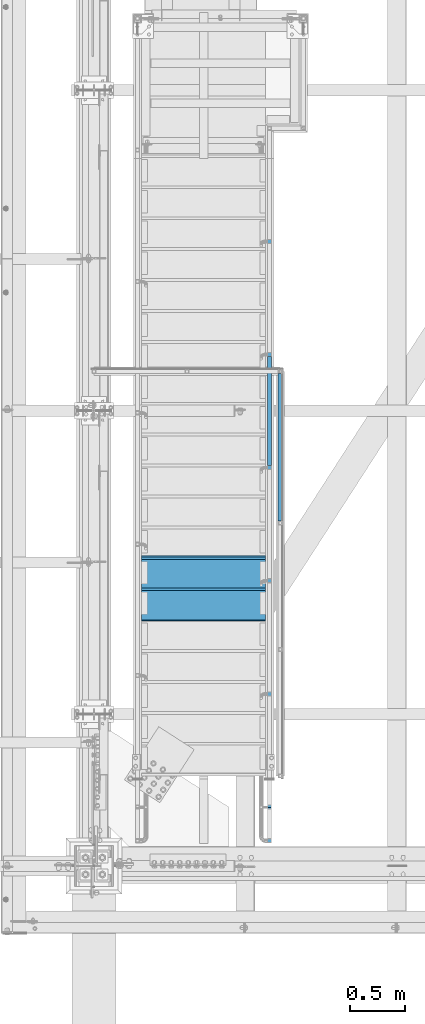
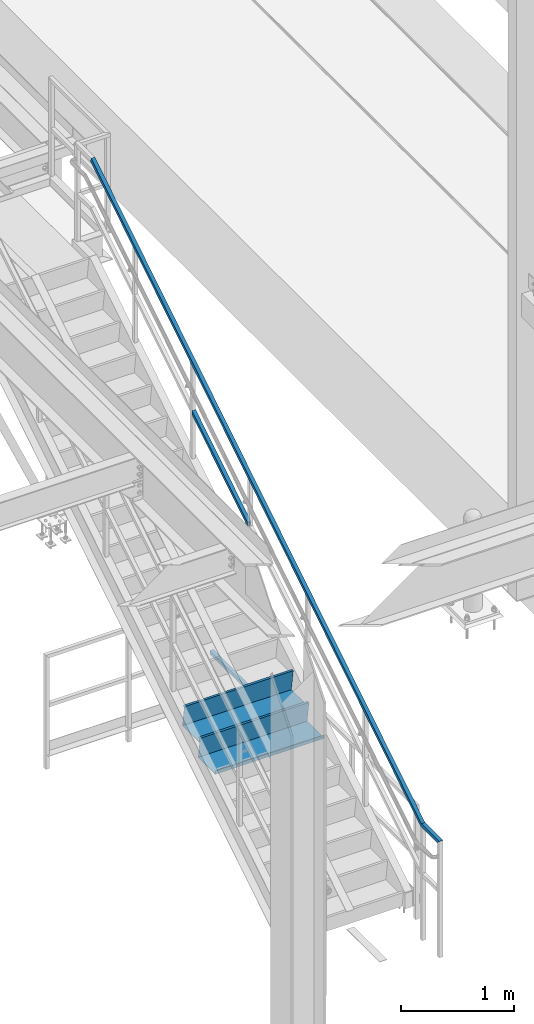
# One storey, part 1746 of 3843: 4 beams, 1 member, 3 elements without a shape of their own.
"""IFC2X3 building model written with IfcOpenShell, lengths in millimetres."""

from ifc_helpers import new_model, si_unit, frame, origin_with_axes, place, context, subcontext, project, spatial, faceted_brep, material, type_object, element, aggregate, save


model = new_model("IFC2X3")

# Units and contexts
model_context = context("Model", 3, precision=1e-05, world=origin_with_axes())
body_context = subcontext(model_context, "Body", "Model", "MODEL_VIEW")
ifc_project = project(units=[si_unit("LENGTHUNIT", "METRE", prefix="MILLI"), si_unit("AREAUNIT", "SQUARE_METRE"), si_unit("VOLUMEUNIT", "CUBIC_METRE"), si_unit("MASSUNIT", "GRAM", prefix="KILO"), si_unit("TIMEUNIT", "SECOND"), si_unit("PLANEANGLEUNIT", "RADIAN"), si_unit("SOLIDANGLEUNIT", "STERADIAN"), si_unit("THERMODYNAMICTEMPERATUREUNIT", "DEGREE_CELSIUS"), si_unit("LUMINOUSINTENSITYUNIT", "LUMEN")], contexts=[model_context])

# Site, building, storey
site_placement = place(None, origin_with_axes())
site = spatial("IfcSite", under=ifc_project, at=site_placement, CompositionType="ELEMENT")
building_placement = place(site_placement, origin_with_axes())
building = spatial("IfcBuilding", under=site, at=building_placement, Name="Undefined", CompositionType="ELEMENT")
storey_placement = place(building_placement, origin_with_axes())
storey = spatial("IfcBuildingStorey", under=building, at=storey_placement, Name="Undefined", CompositionType="ELEMENT", Elevation=0.0)

# Assembly, beam
assembly_1_placement = place(storey_placement, origin_with_axes())
assembly_1 = element("IfcElementAssembly", 1, at=assembly_1_placement, inside=storey, Name="RAIL", AssemblyPlace="NOTDEFINED", PredefinedType="RIGID_FRAME")
ifc_material_1 = material()
beam_type_1 = type_object("IfcBeamType", Name="HSS1-1/2X1-1/2X1/4", PredefinedType="NOTDEFINED")
beam_1_placement = place(assembly_1_placement, frame((38258.75, 28714.6999999812, 31013.4), z_axis=(0.0, 0.0, 1.0), x_axis=(0.0, 1.0, 0.0)))
beam_1 = element("IfcBeam", 2, at=beam_1_placement, type_object=beam_type_1, material=ifc_material_1, Name="RAIL", ObjectType="HSS1-1/2X1-1/2X1/4", context=body_context, shape_type="Brep", body=[
    faceted_brep([(1352.55, -19.0500000000175, 19.0499992350015), (1352.55, -19.0499992350015, -19.0499992350015), (1352.55, 19.0499992350015, -19.0499992350015), (1352.55, 19.0499992350015, 19.0499992350015), (1352.55, -12.6999993299978, 12.6999993300014), (1352.55, 12.6999993299978, 12.6999993300014), (1352.55, 12.6999993299978, -12.6999993300014), (1352.55, -12.6999993299978, -12.6999993300014), (19.0499992350015, 19.0499992350015, -19.0499992350015), (19.0499992350015, 19.0499992350015, 19.0499992350015), (19.0499992350015, -19.0499992350015, 19.0499992350015), (19.0499992350015, -19.0499992350015, -19.0499992350015), (19.0499992350015, 12.6999993299978, 12.6999993299978), (19.0499992350015, -12.6999993299978, 12.6999993299978), (19.0499992350015, -12.6999993299978, -12.6999993299978), (19.0499992350015, 12.6999993299978, -12.6999993299978)], [[[0, 1, 2, 3], [4, 5, 6, 7]], [[8, 9, 3, 2]], [[9, 10, 0, 3]], [[10, 11, 1, 0]], [[11, 8, 2, 1]], [[11, 10, 9, 8], [12, 13, 14, 15]], [[14, 13, 4, 7]], [[15, 14, 7, 6]], [[12, 15, 6, 5]], [[13, 12, 5, 4]]]),
])
aggregate(assembly_1, [beam_1])

# Assembly, beam, member
assembly_2_placement = place(storey_placement, origin_with_axes())
assembly_2 = element("IfcElementAssembly", 3, at=assembly_2_placement, inside=storey, Name="RAIL", AssemblyPlace="NOTDEFINED", PredefinedType="RIGID_FRAME")
beam_2_placement = place(assembly_2_placement, frame((38163.4999999524, 32016.7000000038, 35204.4), z_axis=(0.0, 0.529007926750977, -0.848616882600525), x_axis=(0.0, -0.848616882600525, -0.529007926750977)))
beam_2 = element("IfcBeam", 4, at=beam_2_placement, type_object=beam_type_1, material=ifc_material_1, Name="RAIL", ObjectType="HSS1-1/2X1-1/2X1/4", context=body_context, shape_type="Brep", body=[
    faceted_brep([(-5.45142735134868, 19.0499992350015, -19.0499992349487), (-5.45142735134868, -19.0499992350015, -19.0499992349487), (5.45142732476961, -19.0499992350015, 19.0499992349487), (5.45142732476961, 19.0499992350015, 19.0499992349487), (-3.63428485953773, 12.6999993299978, -12.6999993299632), (3.63428483296593, 12.6999993299978, 12.6999993299632), (3.63428483296593, -12.6999993299978, 12.6999993299632), (-3.63428485953773, -12.6999993299978, -12.6999993299632), (6919.5255172242, -19.0499992350015, 19.0499992162295), (6919.5255172242, 19.0499992350015, 19.0499992162295), (6908.62266256049, 19.0499992350015, -19.0499992536661), (6908.62266256049, -19.0499992350015, -19.0499992536661), (6910.43980505023, -12.6999993299978, -12.6999993486843), (6910.43980505023, 12.6999993299978, -12.6999993486843), (6917.70837473446, 12.6999993299978, 12.6999993112477), (6917.70837473446, -12.6999993299978, 12.6999993112477), (7178.82106607321, 19.0499992350015, -187.485367656507), (7178.82106607321, -19.0499992350015, -187.485367656507), (7166.64396534434, -19.0499992350015, -134.997864528066), (7166.64396534434, 19.0499992350015, -134.997864528066), (7176.79154923393, -12.6999993299978, -178.737450248016), (7176.79154923393, 12.6999993299978, -178.737450248016), (7168.67348218363, 12.6999993299978, -143.745781936559), (7168.67348218363, -12.6999993299978, -143.745781936559)], [[[0, 1, 2, 3], [4, 5, 6, 7]], [[3, 2, 8, 9]], [[1, 0, 10, 11]], [[4, 7, 12, 13]], [[6, 5, 14, 15]], [[11, 10, 16, 17]], [[8, 2, 1, 11, 17, 18]], [[9, 8, 18, 19]], [[10, 0, 3, 9, 19, 16]], [[13, 12, 20, 21]], [[14, 5, 4, 13, 21, 22]], [[15, 14, 22, 23]], [[12, 7, 6, 15, 23, 20]], [[19, 18, 17, 16], [22, 21, 20, 23]]]),
])
member_type = type_object("IfcMemberType", Name="HSS1-1/2X1-1/2X1/4", PredefinedType="NOTDEFINED")
member_placement = place(assembly_2_placement, frame((38163.4999999712, 29216.35, 32925.3272729449), z_axis=(0.0, -0.529007926750979, 0.848616882600523), x_axis=(0.0, 0.848616882600524, 0.529007926750978)))
member = element("IfcMember", 5, at=member_placement, type_object=member_type, material=ifc_material_1, Name="RAIL", ObjectType="HSS1-1/2X1-1/2X1/4", context=body_context, shape_type="Brep", body=[
    faceted_brep([(1194.15206246817, -19.0499999811145, 19.0499992336445), (1170.40141407416, -19.0499992350015, -19.0499992362566), (1170.40141407416, 19.0499992350015, -19.0499992362566), (1194.15206246817, 19.0499992350015, 19.0499992336445), (1190.19362096973, -12.6999993299978, 12.6999993286627), (1190.19362096973, 12.6999993299978, 12.6999993286627), (1174.35985557328, 12.6999993299978, -12.6999993312675), (1174.35985557328, -12.6999993299978, -12.6999993312675), (10.5729683018217, 19.0499992350015, -19.0499992349742), (34.3236166958304, 19.0499992350015, 19.0499992349305), (34.3236166958304, -19.0500000222455, 19.0499992349305), (10.5729683018217, -19.0499992350015, -19.0499992349742), (30.3651751973375, -12.6999993299978, 12.6999993299451), (14.5314098008821, -12.6999993299978, -12.6999993299924), (14.5314098008821, 12.6999993299978, -12.6999993299924), (30.3651751973375, 12.6999993299978, 12.6999993299451)], [[[0, 1, 2, 3], [4, 5, 6, 7]], [[8, 9, 3, 2]], [[9, 10, 0, 3]], [[10, 11, 1, 0]], [[11, 8, 2, 1]], [[10, 9, 8, 11], [12, 13, 14, 15]], [[13, 12, 4, 7]], [[14, 13, 7, 6]], [[15, 14, 6, 5]], [[12, 15, 5, 4]]]),
])
aggregate(assembly_2, [member, beam_2])

# Assembly, beams
assembly_3_placement = place(storey_placement, origin_with_axes())
assembly_3 = element("IfcElementAssembly", 6, at=assembly_3_placement, inside=storey, Name="STAIR", AssemblyPlace="NOTDEFINED", PredefinedType="RIGID_FRAME")
ifc_material_2 = material(Name="STEEL/ASTM A1011")
beam_type_2 = type_object("IfcBeamType", PredefinedType="NOTDEFINED")
beam_3_placement = place(assembly_3_placement, frame((37566.5999999524, 28409.8999999812, 31871.7839285771), z_axis=(1.0, 0.0, 0.0), x_axis=(0.0, -1.0, 0.0)))
beam_3 = element("IfcBeam", 7, at=beam_3_placement, type_object=beam_type_2, material=ifc_material_2, Name="TREAD", context=body_context, shape_type="Brep", body=[
    faceted_brep([(0.0, -1.58750000000146, -558.799999999999), (0.0, -1.58750000000146, 558.799999999999), (0.0, 1.58750000000146, 558.799999999999), (0.0, 1.58750000000146, -558.799999999999), (21.7283948539116, 1.58750000000146, 558.800000000003), (21.7283948539116, 1.58750000000146, -558.800000000003), (25.3999999999942, -1.58750000000146, -558.799999999999), (25.3999999999942, -1.58750000000146, 558.799999999999), (-11.0799384794227, 226.55892857143, 558.800000000003), (-11.0799384794227, 226.55892857143, -558.800000000003), (-7.40833333332557, 223.383928571428, -558.800000000003), (-7.40833333332557, 223.383928571428, 558.800000000003), (293.720061520566, 226.55892857143, 558.800000000003), (293.720061520566, 226.55892857143, -558.800000000003), (290.974498041134, 223.383928571428, -558.800000000003), (290.974498041134, 223.383928571428, 558.800000000003), (299.614357882056, 186.140896378427, 558.800000000003), (299.614357882056, 186.140896378427, -558.800000000003), (296.472590667174, 185.682721992918, 558.800000000003), (296.472590667174, 185.682721992918, -558.800000000003)], [[[0, 1, 2, 3]], [[3, 2, 4, 5]], [[1, 0, 6, 7]], [[5, 4, 8, 9]], [[7, 6, 10, 11]], [[9, 8, 12, 13]], [[11, 10, 14, 15]], [[13, 12, 16, 17]], [[12, 8, 4, 2, 1, 7, 11, 15, 18, 16]], [[15, 14, 19, 18]], [[14, 10, 6, 0, 3, 5, 9, 13, 17, 19]], [[18, 19, 17, 16]]]),
])
beam_4_placement = place(assembly_3_placement, frame((37566.5999999524, 28130.4999999812, 31697.6125000057), z_axis=(1.0, 0.0, 0.0), x_axis=(0.0, -1.0, 0.0)))
beam_4 = element("IfcBeam", 8, at=beam_4_placement, type_object=beam_type_2, material=ifc_material_2, Name="TREAD", context=body_context, shape_type="Brep", body=[
    faceted_brep([(0.0, -1.58750000000146, -558.799999999999), (0.0, -1.58750000000146, 558.799999999999), (0.0, 1.58750000000146, 558.799999999999), (0.0, 1.58750000000146, -558.799999999999), (21.7283948539116, 1.58750000000146, 558.800000000003), (21.7283948539116, 1.58750000000146, -558.800000000003), (25.3999999999942, -1.58750000000146, -558.799999999999), (25.3999999999942, -1.58750000000146, 558.799999999999), (-11.0799384794227, 226.55892857143, 558.800000000003), (-11.0799384794227, 226.55892857143, -558.800000000003), (-7.40833333332557, 223.383928571428, -558.800000000003), (-7.40833333332557, 223.383928571428, 558.800000000003), (293.720061520566, 226.55892857143, 558.800000000003), (293.720061520566, 226.55892857143, -558.800000000003), (290.974498041134, 223.383928571428, -558.800000000003), (290.974498041134, 223.383928571428, 558.800000000003), (299.614357882056, 186.140896378427, 558.800000000003), (299.614357882056, 186.140896378427, -558.800000000003), (296.472590667174, 185.682721992918, 558.800000000003), (296.472590667174, 185.682721992918, -558.800000000003)], [[[0, 1, 2, 3]], [[3, 2, 4, 5]], [[1, 0, 6, 7]], [[5, 4, 8, 9]], [[7, 6, 10, 11]], [[9, 8, 12, 13]], [[11, 10, 14, 15]], [[13, 12, 16, 17]], [[12, 8, 4, 2, 1, 7, 11, 15, 18, 16]], [[15, 14, 19, 18]], [[14, 10, 6, 0, 3, 5, 9, 13, 17, 19]], [[18, 19, 17, 16]]]),
])
aggregate(assembly_3, [beam_3, beam_4])

save(model, "model.ifc")
